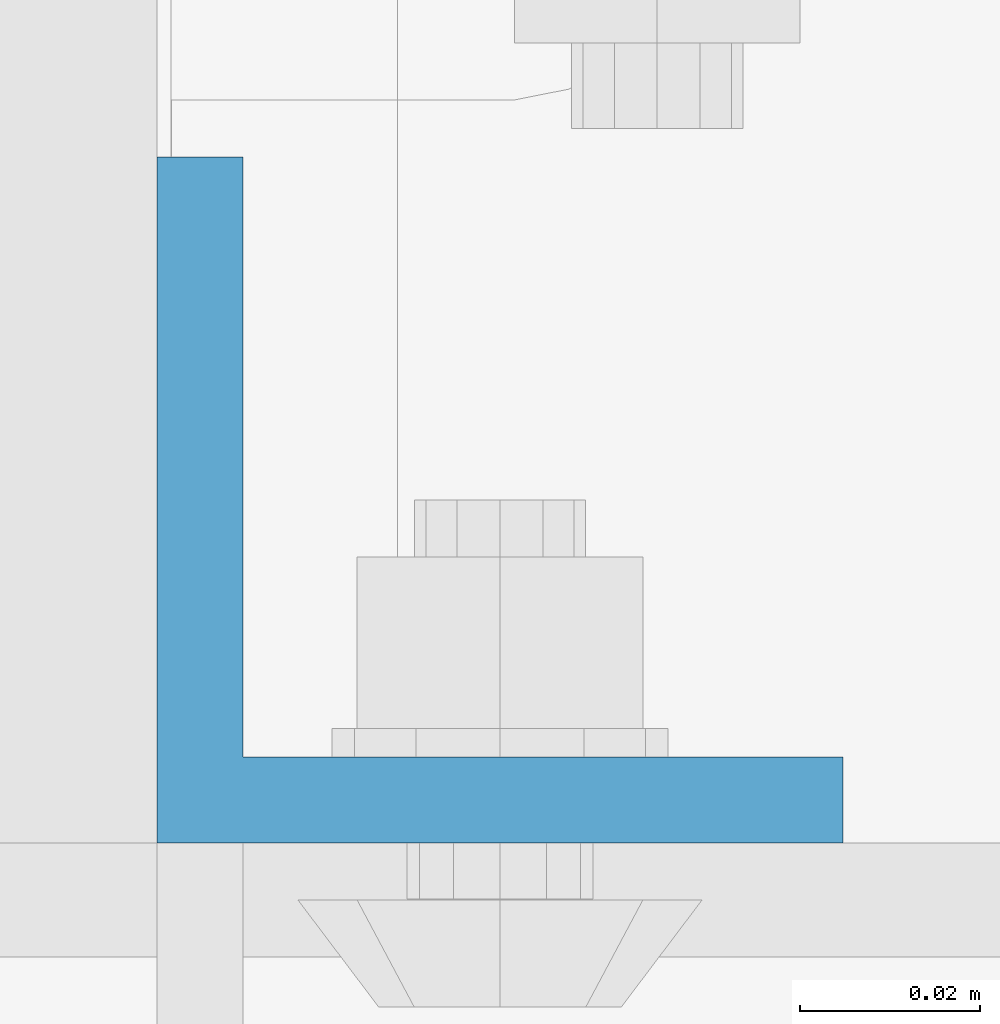
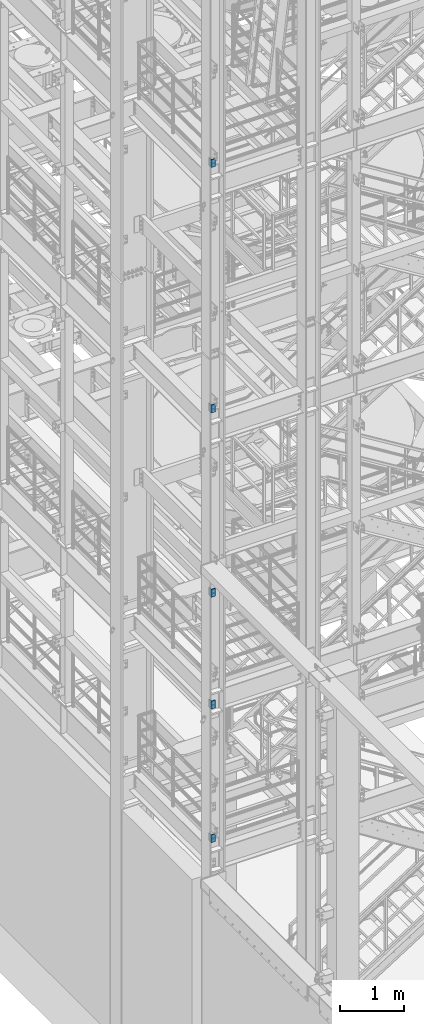
# One storey, part 799 of 1876: 5 columns, 2 elements without a shape of their own.
"""IFC2X3 building model written with IfcOpenShell, lengths in millimetres."""

from ifc_helpers import new_model, si_unit, frame, origin_with_axes, place, context, subcontext, project, spatial, faceted_brep, material, type_object, element, aggregate, save


model = new_model("IFC2X3")

# Units and contexts
model_context = context("Model", 3, precision=1e-05, world=origin_with_axes())
body_context = subcontext(model_context, "Body", "Model", "MODEL_VIEW")
ifc_project = project(units=[si_unit("LENGTHUNIT", "METRE", prefix="MILLI"), si_unit("AREAUNIT", "SQUARE_METRE"), si_unit("VOLUMEUNIT", "CUBIC_METRE"), si_unit("MASSUNIT", "GRAM", prefix="KILO"), si_unit("TIMEUNIT", "SECOND"), si_unit("PLANEANGLEUNIT", "RADIAN"), si_unit("SOLIDANGLEUNIT", "STERADIAN"), si_unit("THERMODYNAMICTEMPERATUREUNIT", "DEGREE_CELSIUS"), si_unit("LUMINOUSINTENSITYUNIT", "LUMEN")], contexts=[model_context])

# Site, building, storey
site_placement = place(None, origin_with_axes())
site = spatial("IfcSite", under=ifc_project, at=site_placement, CompositionType="ELEMENT")
building_placement = place(site_placement, origin_with_axes())
building = spatial("IfcBuilding", under=site, at=building_placement, Name="Undefined", CompositionType="ELEMENT")
storey_placement = place(building_placement, origin_with_axes())
storey = spatial("IfcBuildingStorey", under=building, at=storey_placement, Name="Undefined", CompositionType="ELEMENT", Elevation=0.0)

# Assembly, columns
assembly_1_placement = place(storey_placement, origin_with_axes())
assembly_1 = element("IfcElementAssembly", 1, at=assembly_1_placement, inside=storey, Name="COLUMN", AssemblyPlace="NOTDEFINED", PredefinedType="RIGID_FRAME")
ifc_material = material(Name="STEEL/A36")
column_type = type_object("IfcColumnType", Name="L3X3X3/8", PredefinedType="NOTDEFINED")
column_1_placement = place(assembly_1_placement, frame((-74.6125, -7204.075, 7859.7125), z_axis=(1.0, 0.0, 0.0), x_axis=(0.0, 0.0, 1.0)))
column_1 = element("IfcColumn", 2, at=column_1_placement, type_object=column_type, material=ifc_material, Name="ANGLE", ObjectType="L3X3X3/8", context=body_context, shape_type="Brep", body=[
    faceted_brep([(0.0, 38.1000000000004, -38.1), (0.0, 38.1000000000004, 38.1), (152.4, 38.1000000000004, 38.1), (152.4, 38.1000000000004, -38.1), (0.0, 28.5749999999998, 38.1), (152.4, 28.5749999999998, 38.1), (0.0, 28.5749999999998, -28.575), (152.4, 28.5749999999998, -28.575), (0.0, -38.1000000000004, -28.575), (152.4, -38.1000000000004, -28.575), (0.0, -38.1000000000004, -38.1), (152.4, -38.1000000000004, -38.1)], [[[0, 1, 2, 3]], [[1, 4, 5, 2]], [[4, 6, 7, 5]], [[6, 8, 9, 7]], [[8, 10, 11, 9]], [[10, 0, 3, 11]], [[5, 7, 9, 11, 3, 2]], [[10, 8, 6, 4, 1, 0]]]),
])
column_2_placement = place(assembly_1_placement, frame((-74.6125, -7204.075, 9993.3125), z_axis=(1.0, 0.0, 0.0), x_axis=(0.0, 0.0, 1.0)))
column_2 = element("IfcColumn", 3, at=column_2_placement, type_object=column_type, material=ifc_material, Name="ANGLE", ObjectType="L3X3X3/8", context=body_context, shape_type="Brep", body=[
    faceted_brep([(0.0, 38.1000000000004, -38.1), (0.0, 38.1000000000004, 38.1), (152.4, 38.1000000000004, 38.1), (152.4, 38.1000000000004, -38.1), (0.0, 28.5749999999998, 38.1), (152.4, 28.5749999999998, 38.1), (0.0, 28.5749999999998, -28.575), (152.4, 28.5749999999998, -28.575), (0.0, -38.1000000000004, -28.575), (152.4, -38.1000000000004, -28.575), (0.0, -38.1000000000004, -38.1), (152.4, -38.1000000000004, -38.1)], [[[0, 1, 2, 3]], [[1, 4, 5, 2]], [[4, 6, 7, 5]], [[6, 8, 9, 7]], [[8, 10, 11, 9]], [[10, 0, 3, 11]], [[5, 7, 9, 11, 3, 2]], [[10, 8, 6, 4, 1, 0]]]),
])
column_3_placement = place(assembly_1_placement, frame((-74.6125, -7204.075, 5308.6), z_axis=(1.0, 0.0, 0.0), x_axis=(0.0, 0.0, 1.0)))
column_3 = element("IfcColumn", 4, at=column_3_placement, type_object=column_type, material=ifc_material, Name="ANGLE", ObjectType="L3X3X3/8", context=body_context, shape_type="Brep", body=[
    faceted_brep([(0.0, 38.1000000000004, -38.1), (0.0, 38.1000000000004, 38.1), (152.4, 38.1000000000004, 38.1), (152.4, 38.1000000000004, -38.1), (0.0, 28.5749999999998, 38.1), (152.4, 28.5749999999998, 38.1), (0.0, 28.5749999999998, -28.575), (152.4, 28.5749999999998, -28.575), (0.0, -38.1000000000004, -28.575), (152.4, -38.1000000000004, -28.575), (0.0, -38.1000000000004, -38.1), (152.4, -38.1000000000004, -38.1)], [[[0, 1, 2, 3]], [[1, 4, 5, 2]], [[4, 6, 7, 5]], [[6, 8, 9, 7]], [[8, 10, 11, 9]], [[10, 0, 3, 11]], [[5, 7, 9, 11, 3, 2]], [[10, 8, 6, 4, 1, 0]]]),
])

# Assembly, column
assembly_2_placement = place(storey_placement, origin_with_axes())
assembly_2 = element("IfcElementAssembly", 5, at=assembly_2_placement, inside=storey, Name="COLUMN", AssemblyPlace="NOTDEFINED", PredefinedType="RIGID_FRAME")
column_4_placement = place(assembly_2_placement, frame((-74.6125, -7204.07500000374, 18199.1), z_axis=(1.0, 0.0, 0.0), x_axis=(0.0, 0.0, 1.0)))
column_4 = element("IfcColumn", 6, at=column_4_placement, type_object=column_type, material=ifc_material, Name="ANGLE", ObjectType="L3X3X3/8", context=body_context, shape_type="Brep", body=[
    faceted_brep([(0.0, 38.1000000000004, -38.1), (0.0, 38.1000000000004, 38.1), (152.4, 38.1000000000004, 38.1), (152.4, 38.1000000000004, -38.1), (0.0, 28.5749999999998, 38.1), (152.4, 28.5749999999998, 38.1), (0.0, 28.5749999999998, -28.575), (152.4, 28.5749999999998, -28.575), (0.0, -38.1000000000004, -28.575), (152.4, -38.1000000000004, -28.575), (0.0, -38.1000000000004, -38.1), (152.4, -38.1000000000004, -38.1)], [[[0, 1, 2, 3]], [[1, 4, 5, 2]], [[4, 6, 7, 5]], [[6, 8, 9, 7]], [[8, 10, 11, 9]], [[10, 0, 3, 11]], [[5, 7, 9, 11, 3, 2]], [[10, 8, 6, 4, 1, 0]]]),
])
aggregate(assembly_2, [column_4])

# Column
column_5_placement = place(assembly_1_placement, frame((-74.6125, -7204.075, 13512.8), z_axis=(1.0, 0.0, 0.0), x_axis=(0.0, 0.0, 1.0)))
column_5 = element("IfcColumn", 7, at=column_5_placement, type_object=column_type, material=ifc_material, Name="ANGLE", ObjectType="L3X3X3/8", context=body_context, shape_type="Brep", body=[
    faceted_brep([(0.0, 38.1000000000004, -38.1), (0.0, 38.1000000000004, 38.1), (152.4, 38.1000000000004, 38.1), (152.4, 38.1000000000004, -38.1), (0.0, 28.5749999999998, 38.1), (152.4, 28.5749999999998, 38.1), (0.0, 28.5749999999998, -28.575), (152.4, 28.5749999999998, -28.575), (0.0, -38.1000000000004, -28.575), (152.4, -38.1000000000004, -28.575), (0.0, -38.1000000000004, -38.1), (152.4, -38.1000000000004, -38.1)], [[[0, 1, 2, 3]], [[1, 4, 5, 2]], [[4, 6, 7, 5]], [[6, 8, 9, 7]], [[8, 10, 11, 9]], [[10, 0, 3, 11]], [[5, 7, 9, 11, 3, 2]], [[10, 8, 6, 4, 1, 0]]]),
])

aggregate(assembly_1, [column_1, column_2, column_3, column_5])

save(model, "model.ifc")
